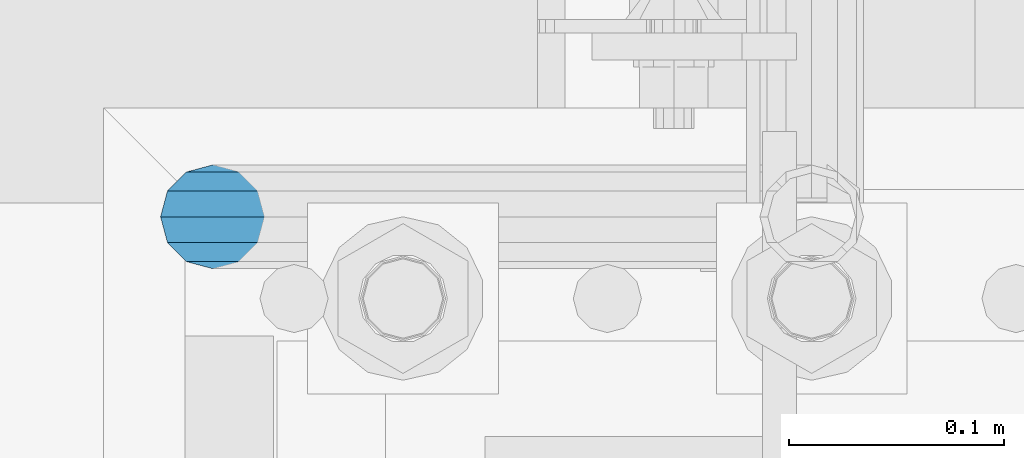
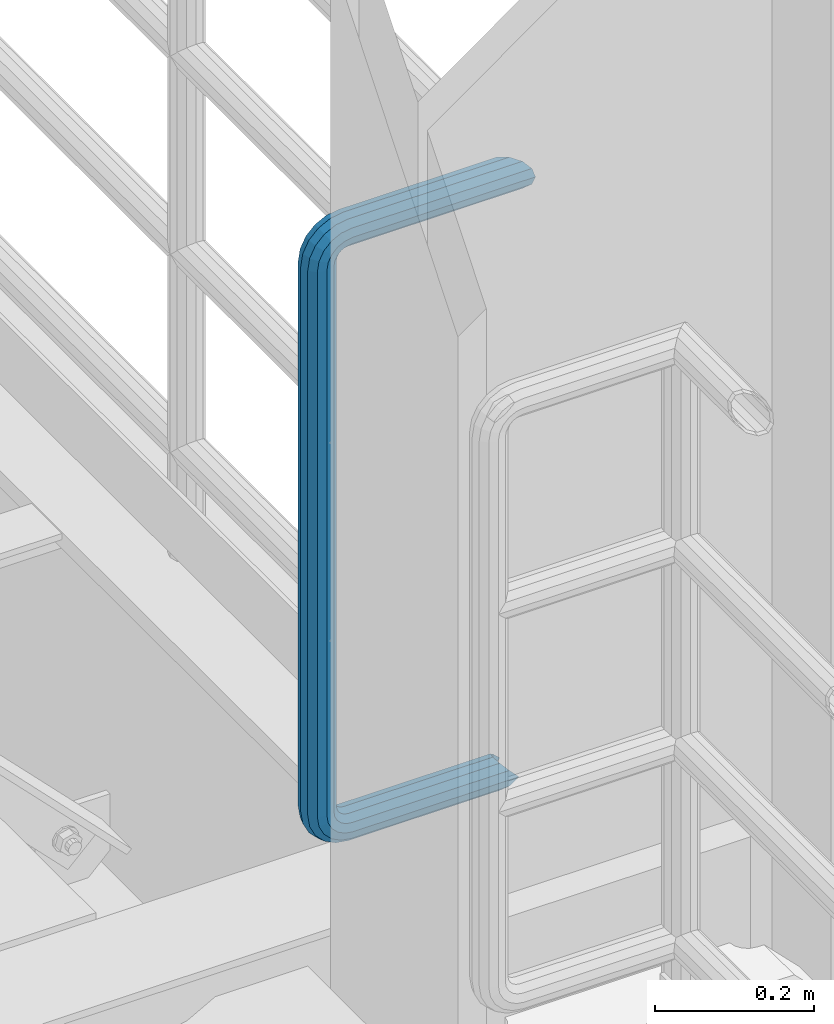
# One storey, part 991 of 1876: 1 beam, 1 element without a shape of its own.
"""IFC2X3 building model written with IfcOpenShell, lengths in millimetres."""

from ifc_helpers import new_model, si_unit, frame, origin_with_axes, place, context, subcontext, project, spatial, faceted_brep, material, type_object, element, aggregate, save


model = new_model("IFC2X3")

# Units and contexts
model_context = context("Model", 3, precision=1e-05, world=origin_with_axes())
body_context = subcontext(model_context, "Body", "Model", "MODEL_VIEW")
ifc_project = project(units=[si_unit("LENGTHUNIT", "METRE", prefix="MILLI"), si_unit("AREAUNIT", "SQUARE_METRE"), si_unit("VOLUMEUNIT", "CUBIC_METRE"), si_unit("MASSUNIT", "GRAM", prefix="KILO"), si_unit("TIMEUNIT", "SECOND"), si_unit("PLANEANGLEUNIT", "RADIAN"), si_unit("SOLIDANGLEUNIT", "STERADIAN"), si_unit("THERMODYNAMICTEMPERATUREUNIT", "DEGREE_CELSIUS"), si_unit("LUMINOUSINTENSITYUNIT", "LUMEN")], contexts=[model_context])

# Site, building, storey
site_placement = place(None, origin_with_axes())
site = spatial("IfcSite", under=ifc_project, at=site_placement, CompositionType="ELEMENT")
building_placement = place(site_placement, origin_with_axes())
building = spatial("IfcBuilding", under=site, at=building_placement, Name="Undefined", CompositionType="ELEMENT")
storey_placement = place(building_placement, origin_with_axes())
storey = spatial("IfcBuildingStorey", under=building, at=storey_placement, Name="Undefined", CompositionType="ELEMENT", Elevation=0.0)

# Assembly, beam
assembly_placement = place(storey_placement, origin_with_axes())
assembly = element("IfcElementAssembly", 1, at=assembly_placement, inside=storey, Name="RAIL", AssemblyPlace="NOTDEFINED", PredefinedType="RIGID_FRAME")
ifc_material = material()
beam_type = type_object("IfcBeamType", Name="PIPE1-1/2SCH40", PredefinedType="NOTDEFINED")
beam_placement = place(assembly_placement, frame((7620.00000000001, -4356.1, 6207.125), z_axis=(0.0, 0.0, 1.0), x_axis=(-1.0, 0.0, 0.0)))
beam = element("IfcBeam", 2, at=beam_placement, type_object=beam_type, material=ifc_material, Name="RAIL", ObjectType="PIPE1-1/2SCH40", context=body_context, shape_type="Brep", body=[
    faceted_brep([(1.20714750983051e-12, 24.1299999999974, -914.399963378906), (12.0650000000014, 20.8971929933159, -926.464963378905), (12.0650000000014, 20.8971929933177, -902.334963378908), (12.0650000000014, -20.8971929933195, -902.334963378908), (12.0650000000014, -20.8971929933195, -926.464963378905), (1.52133659548828e-12, -24.130000000001, -914.399963378906), (20.8971929933199, -12.0650000000023, -893.502770385589), (20.8971929933199, -12.0650000000005, -898.533841947723), (15.2545715621378, -17.7076214311819, -904.176463378906), (12.5151929933181, -20.4470000000019, -914.399963378906), (15.2545715621376, -17.7076214311819, -924.623463378906), (20.8971929933199, -12.0650000000005, -930.26608481009), (20.8971929933199, -12.0650000000023, -935.297156372224), (24.1300000000014, -1.81898940354586e-12, -934.846963378906), (24.1300000000014, -1.81898940354586e-12, -938.529963378907), (21.3906214311813, -10.2235000000019, -932.107584810088), (21.3906214311823, 10.2234999999982, -932.107584810088), (20.8971929933199, 12.0650000000005, -930.266084810086), (20.8971929933199, 12.0649999999987, -935.297156372224), (15.2545715621413, 17.7076214311783, -924.623463378906), (12.5151929933216, 20.4469999999983, -914.399963378906), (15.2545715621411, 17.7076214311783, -904.176463378906), (20.8971929933199, 12.0650000000005, -898.533841947727), (20.8971929933199, 12.0649999999987, -893.502770385589), (21.3906214311822, 10.2234999999982, -896.692341947724), (24.1300000000014, 0.0, -893.952963378906), (24.1300000000014, 0.0, -890.269963378905), (21.3906214311814, -10.2235000000019, -896.692341947724), (241.299995422363, -20.8971929933177, 12.0649999999987), (241.299995422363, -24.1299999999992, 0.0), (253.073542436527, -24.1299999999992, -1.86474665447167), (256.801832473661, -20.8971929933177, 9.60975021462946), (241.299995422363, -12.0650000000005, 20.8971929933177), (259.531130206197, -12.0650000000005, 18.0096649141014), (241.299995422363, 0.0, 24.130000000001), (260.530122510796, 0.0, 21.084247083727), (241.299995422363, 12.0650000000005, 20.8971929933177), (259.531130206197, 12.0650000000005, 18.0096649141014), (241.299995422363, 20.8971929933177, 12.0649999999987), (256.801832473661, 20.8971929933177, 9.60975021462946), (241.299995422363, 24.1299999999992, 0.0), (253.073542436527, 24.1299999999992, -1.86474665447167), (241.299995422363, 20.8971929933177, -12.0649999999987), (249.345252399393, 20.8971929933177, -13.3392435235728), (241.299995422363, 12.0650000000005, -20.8971929933177), (246.615954666858, 12.0650000000005, -21.7391582230448), (241.299995422363, 0.0, -24.130000000001), (245.616962362259, 0.0, -24.8137403926739), (241.299995422363, -12.0650000000005, -20.8971929933177), (246.615954666858, -12.0650000000005, -21.7391582230448), (241.299995422363, -20.8971929933177, -12.0649999999987), (249.345252399393, -20.8971929933177, -13.3392435235728), (267.334993896485, 20.8971929933177, -38.0999984741211), (279.399993896485, 24.1299999999992, -38.0999984741211), (279.399993896484, 24.1299999999992, -876.299964904785), (267.334993896484, 20.8971929933177, -876.299964904785), (291.464993896486, 20.8971929933177, -38.0999984741211), (291.464993896484, 20.8971929933177, -876.299964904785), (300.297186889804, 12.0650000000005, -38.0999984741211), (300.297186889803, 12.0650000000005, -876.299964904785), (303.529993896486, 0.0, -38.0999984741211), (303.529993896484, 0.0, -876.299964904785), (300.297186889804, -12.0650000000005, -38.0999984741211), (300.297186889803, -12.0650000000005, -876.299964904785), (291.464993896486, -20.8971929933177, -38.0999984741211), (291.464993896484, -20.8971929933177, -876.299964904785), (279.399993896484, -24.1299999999992, -38.0999984741211), (279.399993896484, -24.1299999999992, -876.299964904785), (267.334993896485, -20.8971929933177, -38.0999984741211), (267.334993896484, -20.8971929933177, -876.299964904785), (258.502800903167, -12.0650000000005, -38.0999984741211), (258.502800903166, -12.0650000000005, -876.299964904785), (255.269993896485, 0.0, -38.0999984741211), (255.269993896484, 0.0, -876.299964904785), (258.502800903167, 12.0650000000005, -38.0999984741211), (258.502800903166, 12.0650000000005, -876.299964904785), (257.660835673438, 12.0650000000005, -881.615924149282), (254.586253503809, 0.0, -880.616931844681), (257.660835673438, -12.0650000000005, -881.615924149282), (266.06075037291, -20.8971929933177, -884.345221881817), (277.535247242011, -24.130000000001, -888.073511918952), (289.009744111112, -20.8971929933195, -891.801801956084), (297.409658810584, -12.0650000000005, -894.531099688622), (300.484240980214, 0.0, -895.53009199322), (297.409658810584, 12.0650000000005, -894.531099688622), (289.009744111112, 20.8971929933177, -891.801801956084), (277.535247242011, 24.1299999999992, -888.073511918952), (266.06075037291, 20.8971929933177, -884.345221881817), (241.299995422364, -1.81898940354586e-12, -938.529963378911), (241.299995422364, -12.0650000000005, -935.297156372228), (241.299995422364, -20.8971929933195, -926.464963378909), (241.299995422363, -24.130000000001, -914.399963378906), (241.299995422363, -20.8971929933195, -902.334963378908), (241.299995422363, -12.0650000000005, -893.502770385589), (241.299995422363, 0.0, -890.269963378909), (241.299995422364, 20.8971929933177, -926.464963378909), (241.299995422364, 12.0649999999987, -935.297156372228), (241.299995422364, 24.1299999999992, -914.39996337891), (241.299995422363, 20.8971929933177, -902.334963378908), (241.299995422363, 12.0649999999987, -893.502770385589), (260.530122510801, 0.0, -935.484210462637), (259.531130206202, 12.0649999999987, -932.409628293008), (259.531130206201, -12.0650000000005, -932.409628293008), (256.801832473666, -20.8971929933195, -924.009713593536), (253.07354243653, -24.130000000001, -912.535216724435), (249.345252399395, -20.8971929933195, -901.060719855333), (246.615954666859, -12.0650000000005, -892.660805155861), (245.61696236226, 0.0, -889.586222986232), (246.615954666859, 12.0649999999987, -892.660805155861), (249.345252399395, 20.8971929933177, -901.060719855333), (253.07354243653, 24.1299999999992, -912.535216724435), (256.801832473666, 20.8971929933177, -924.009713593536), (275.977674493594, 12.0649999999987, -924.029695422345), (270.786241706733, 20.8971929933177, -916.884301193139), (277.877870775644, 0.0, -926.645091230272), (275.977674493608, -12.0650000000005, -924.029695422334), (270.786241706733, -20.8971929933195, -916.884301193139), (263.694612637823, -24.130000000001, -907.123511156005), (256.602983568912, -20.8971929933195, -897.362721118872), (251.411550782037, -12.0650000000005, -890.21732688968), (249.511354500001, 0.0, -887.601931081743), (251.411550782037, 12.0650000000005, -890.21732688968), (256.602983568912, 20.8971929933177, -897.362721118872), (263.694612637823, 24.1299999999992, -907.123511156005), (281.884331710718, 20.8971929933177, -905.786211189152), (272.123541673585, 24.1299999999992, -898.694582120243), (289.029725939912, 12.0650000000005, -910.977643976028), (291.645121747852, 0.0, -912.877840258065), (289.029725939912, -12.0650000000005, -910.977643976028), (281.884331710718, -20.8971929933195, -905.786211189152), (272.123541673585, -24.130000000001, -898.694582120243), (262.362751636451, -20.8971929933195, -891.602953051333), (255.217357407258, -12.0650000000005, -886.411520264461), (252.601961599318, 0.0, -884.511323982424), (255.217357407258, 12.0650000000005, -886.411520264461), (262.362751636451, 20.8971929933177, -891.602953051333), (266.060750372911, 20.8971929933177, -30.0547414970897), (257.660835673439, 12.0650000000005, -32.7840392296275), (277.535247242011, 24.1299999999992, -26.3264514599541), (289.009744111112, 20.8971929933177, -22.5981614228222), (297.409658810584, 12.0650000000005, -19.8688636902843), (300.484240980213, 0.0, -18.8698713856866), (297.409658810584, -12.0650000000005, -19.8688636902843), (289.009744111112, -20.8971929933177, -22.5981614228222), (277.535247242011, -24.1299999999992, -26.3264514599541), (266.060750372911, -20.8971929933177, -30.0547414970897), (257.660835673439, -12.0650000000005, -32.7840392296275), (254.58625350381, 0.0, -33.7830315342253), (255.217357407257, 12.0650000000005, -27.9884431144455), (252.601961599318, 0.0, -29.8886393964822), (262.362751636451, 20.8971929933177, -22.7970103275729), (272.123541673583, 24.1299999999992, -15.7053812586601), (281.884331710716, 20.8971929933177, -8.61375218975081), (289.029725939909, 12.0650000000005, -3.42231940287456), (291.645121747848, 0.0, -1.52212312084157), (289.029725939909, -12.0650000000005, -3.42231940287456), (281.884331710716, -20.8971929933177, -8.61375218975081), (272.123541673583, -24.1299999999992, -15.7053812586601), (262.362751636451, -20.8971929933177, -22.7970103275729), (255.217357407257, -12.0650000000005, -27.9884431144455), (249.511354500002, 0.0, -26.7980322971671), (251.411550782037, -12.0650000000005, -24.1826364892258), (251.411550782037, 12.0650000000005, -24.1826364892258), (256.602983568912, 20.8971929933177, -17.037242260034), (263.694612637822, 24.1299999999992, -7.27645222290084), (270.786241706732, 20.8971929933177, 2.48433781423228), (275.977674493607, 12.0650000000005, 9.62973204342416), (277.877870775642, 0.0, 12.2451278513654), (275.977674493607, -12.0650000000005, 9.62973204342416), (270.786241706732, -20.8971929933177, 2.48433781423228), (263.694612637822, -24.1299999999992, -7.27645222290084), (256.602983568912, -20.8971929933177, -17.037242260034), (24.1299999999854, -24.1299999999992, 0.0), (20.8971929933039, -20.8971929933177, -12.0649999999987), (12.0649999999854, -12.0650000000005, -20.8971929933177), (20.8971929933249, -12.0650000000005, -20.8971929933177), (16.4810997545745, -16.4810997545883, -16.48109323873), (24.1300000000063, 0.0, -24.130000000001), (-1.45519152283669e-11, 0.0, -24.130000000001), (20.8971929933249, 12.0650000000005, -20.8971929933177), (-12.0650000000145, 12.0650000000005, -20.8971929933177), (-20.897192993333, 20.8971929933177, -12.0649999999987), (-12.0649999999986, 20.8971929933177, -12.0649999999987), (12.0650000000064, 20.8971929933177, -12.0649999999987), (-16.481093238746, 16.4810932387318, -16.4810997545865), (0.0, 24.1299999999992, 0.0), (-24.1300000000145, 24.1299999999992, 0.0), (-20.897192993333, 20.8971929933177, 12.0649999999987), (-12.0650000000145, 12.0650000000005, 20.8971929933177), (-1.45519152283669e-11, 0.0, 24.130000000001), (12.0649999999854, -12.0650000000005, 20.8971929933177), (20.8971929933039, -20.8971929933177, 12.0649999999987), (241.299995422363, -17.7076214311801, 10.2235000000001), (241.299995422363, -20.4470000000001, 0.0), (20.4469999999854, -20.4470000000001, 0.0), (17.7076214311658, -17.7076214311801, 10.2235000000001), (241.299995422363, 0.0, 20.4470000000001), (241.299995422363, -10.2235000000001, 17.7076214311819), (10.2234999999854, -10.2235000000001, 17.7076214311819), (-1.45519152283669e-11, 0.0, 20.4470000000001), (241.299995422363, 10.2235000000001, 17.7076214311819), (-10.2235000000145, 10.2235000000001, 17.7076214311819), (241.299995422363, 17.7076214311801, 10.2235000000001), (-17.7076214311949, 17.7076214311801, 10.2235000000001), (241.299995422363, 20.4470000000001, 0.0), (-20.4470000000145, 20.4470000000001, 0.0), (241.299995422363, 17.7076214311801, -10.2235000000001), (-17.7076214311949, 17.7076214311801, -10.2235000000001), (241.299995422363, 10.2235000000001, -17.7076214311819), (-10.2235000000145, 10.2235000000001, -17.7076214311819), (241.299995422363, 0.0, -20.4470000000001), (-1.45519152283669e-11, 0.0, -20.4470000000001), (241.299995422363, -10.2235000000001, -17.7076214311819), (10.2234999999854, -10.2235000000001, -17.7076214311819), (241.299995422363, -17.7076214311801, -10.2235000000001), (17.7076214311658, -17.7076214311801, -10.2235000000001), (258.545498388721, -10.2235000000001, 14.9762020957387), (256.23277767852, -17.7076214311801, 7.85837963987069), (253.073542436527, -20.4470000000001, -1.86474665447167), (249.914307194535, -17.7076214311801, -11.5878729488177), (247.601586484334, -10.2235000000001, -18.7056954046857), (246.755071952542, 0.0, -21.31099924316), (247.601586484334, 10.2235000000001, -18.7056954046857), (249.914307194535, 17.7076214311801, -11.5878729488177), (253.073542436527, 20.4470000000001, -1.86474665447167), (256.23277767852, 17.7076214311801, 7.85837963987069), (258.545498388721, 10.2235000000001, 14.9762020957387), (259.392012920513, 0.0, 17.5815059342131), (275.713057691449, 0.0, 9.26551826108334), (274.10289136825, -10.2235000000001, 7.04931444488102), (274.10289136825, 10.2235000000001, 7.04931444488102), (269.703835164635, 17.7076214311801, 0.994533019089431), (263.694612637822, 20.4470000000001, -7.27645222290084), (257.685390111009, 17.7076214311801, -15.5474374648911), (253.286333907394, 10.2235000000001, -21.6022188906827), (251.676167584195, 0.0, -23.818422706885), (253.286333907394, -10.2235000000001, -21.6022188906827), (257.685390111009, -17.7076214311801, -15.5474374648911), (263.694612637822, -20.4470000000001, -7.27645222290084), (269.703835164635, -17.7076214311801, 0.994533019089431), (286.449308341364, -10.2235000000001, -5.29710252823133), (280.394526915574, -17.7076214311801, -9.69615873184739), (288.665512157566, 0.0, -3.68693620503473), (286.449308341364, 10.2235000000001, -5.29710252823133), (280.394526915574, 17.7076214311801, -9.69615873184739), (272.123541673583, 20.4470000000001, -15.7053812586601), (263.852556431592, 17.7076214311801, -21.7146037854764), (257.797775005802, 10.2235000000001, -26.1136599890888), (255.581571189601, 0.0, -27.723826312289), (257.797775005802, -10.2235000000001, -26.1136599890888), (263.852556431592, -17.7076214311801, -21.7146037854764), (272.123541673583, -20.4470000000001, -15.7053812586601), (287.258373536355, -17.7076214311801, -23.1672162179639), (277.535247242011, -20.4470000000001, -26.3264514599541), (294.376195992223, -10.2235000000001, -20.8544955077632), (296.981499830698, 0.0, -20.00798097597), (294.376195992223, 10.2235000000001, -20.8544955077632), (287.258373536355, 17.7076214311801, -23.1672162179639), (277.535247242011, 20.4470000000001, -26.3264514599541), (267.812120947668, 17.7076214311801, -29.485686701948), (260.6942984918, 10.2235000000001, -31.7984074121487), (258.088994653325, 0.0, -32.6449219439419), (260.6942984918, -10.2235000000001, -31.7984074121487), (267.812120947668, -17.7076214311801, -29.485686701948), (279.399993896484, -20.4470000000001, -38.0999984741211), (269.176493896485, -17.7076214311801, -38.0999984741211), (289.623493896486, -17.7076214311801, -38.0999984741211), (297.107615327666, -10.2235000000001, -38.0999984741211), (299.846993896486, 0.0, -38.0999984741211), (297.107615327666, 10.2235000000001, -38.0999984741211), (289.623493896486, 17.7076214311801, -38.0999984741211), (279.399993896485, 20.4470000000001, -38.0999984741211), (269.176493896485, 17.7076214311801, -38.0999984741211), (261.692372465305, 10.2235000000001, -38.0999984741211), (258.952993896485, 0.0, -38.0999984741211), (261.692372465305, -10.2235000000001, -38.0999984741211), (269.176493896484, -17.7076214311801, -876.299964904785), (261.692372465304, -10.2235000000001, -876.299964904785), (258.952993896484, 0.0, -876.299964904785), (261.692372465304, 10.2235000000001, -876.299964904785), (269.176493896484, 17.7076214311801, -876.299964904785), (279.399993896484, 20.4470000000001, -876.299964904785), (289.623493896484, 17.7076214311801, -876.299964904785), (297.107615327665, 10.2235000000001, -876.299964904785), (299.846993896484, 0.0, -876.299964904785), (297.107615327665, -10.2235000000001, -876.299964904785), (289.623493896484, -17.7076214311801, -876.299964904785), (279.399993896484, -20.4470000000001, -876.299964904785), (277.535247242011, -20.4470000000001, -888.073511918952), (267.812120947667, -17.7076214311801, -884.914276676958), (260.694298491799, -10.2235000000001, -882.601555966758), (258.088994653324, 0.0, -881.755041434964), (260.694298491799, 10.2235000000001, -882.601555966758), (267.812120947668, 17.7076214311801, -884.914276676958), (277.535247242011, 20.4470000000001, -888.073511918952), (287.258373536355, 17.7076214311801, -891.232747160942), (294.376195992223, 10.2235000000001, -893.545467871143), (296.981499830699, 0.0, -894.391982402936), (294.376195992223, -10.2235000000001, -893.545467871143), (287.258373536355, -17.7076214311801, -891.232747160942), (280.394526915577, -17.7076214311801, -904.703804647055), (272.123541673585, -20.4470000000001, -898.694582120243), (286.449308341367, -10.2235000000001, -909.102860850671), (288.665512157569, 0.0, -910.713027173868), (286.449308341367, 10.2235000000001, -909.102860850671), (280.394526915577, 17.7076214311801, -904.703804647055), (272.123541673585, 20.4470000000001, -898.694582120243), (263.852556431593, 17.7076214311801, -892.68535959343), (257.797775005802, 10.2235000000001, -888.286303389817), (255.581571189601, 0.0, -886.676137066617), (257.797775005802, -10.2235000000001, -888.286303389817), (263.852556431593, -17.7076214311801, -892.68535959343), (263.694612637823, -20.4470000000001, -907.123511156005), (257.685390111009, -17.7076214311801, -898.852525914015), (269.703835164636, -17.7076214311801, -915.394496397999), (274.102891368238, -10.2235000000001, -921.449277823798), (275.71305769145, 0.0, -923.66548163999), (274.102891368251, 10.2235000000001, -921.449277823787), (269.703835164636, 17.7076214311801, -915.394496397999), (263.694612637823, 20.4470000000001, -907.123511156005), (257.685390111009, 17.7076214311801, -898.852525914015), (253.286333907394, 10.2235000000001, -892.797744488227), (251.676167584195, 0.0, -890.581540672025), (253.286333907394, -10.2235000000001, -892.797744488227), (249.914307194537, -17.7076214311801, -902.812090430092), (247.601586484335, -10.2235000000001, -895.694267974224), (253.07354243653, -20.4470000000001, -912.535216724435), (256.232777678524, -17.7076214311819, -922.258343018777), (258.545498388725, -10.2235000000001, -929.376165474645), (259.392012920517, 0.0, -931.981469313119), (258.545498388725, 10.2235000000001, -929.376165474645), (256.232777678524, 17.7076214311801, -922.258343018777), (253.07354243653, 20.4470000000001, -912.535216724435), (249.914307194537, 17.7076214311801, -902.812090430092), (247.601586484335, 10.2235000000001, -895.694267974224), (246.755071952543, 0.0, -893.088964135746), (241.299995422363, -10.2235000000001, -896.692341947728), (241.299995422363, 0.0, -893.95296337891), (241.299995422363, -17.7076214311819, -904.17646337891), (241.299995422363, -20.4470000000001, -914.399963378906), (241.299995422364, -17.7076214311819, -924.62346337891), (241.299995422364, -10.2235000000001, -932.107584810088), (241.299995422364, -1.81898940354586e-12, -934.84696337891), (241.299995422364, 10.2234999999982, -932.107584810088), (241.299995422364, 17.7076214311801, -924.62346337891), (241.299995422364, 20.4470000000001, -914.39996337891), (241.299995422363, 17.7076214311801, -904.17646337891), (241.299995422363, 10.2235000000001, -896.692341947728)], [[[0, 1, 2]], [[3, 4, 5]], [[6, 7, 8, 9, 10, 11, 12, 4, 3]], [[13, 14, 12, 11, 15]], [[16, 17, 18, 14, 13]], [[2, 1, 18, 17, 19, 20, 21, 22, 23]], [[23, 22, 24, 25, 26]], [[26, 25, 27, 7, 6]], [[28, 29, 30, 31]], [[32, 28, 31, 33]], [[34, 32, 33, 35]], [[36, 34, 35, 37]], [[38, 36, 37, 39]], [[40, 38, 39, 41]], [[42, 40, 41, 43]], [[44, 42, 43, 45]], [[46, 44, 45, 47]], [[48, 46, 47, 49]], [[50, 48, 49, 51]], [[52, 53, 54, 55]], [[53, 56, 57, 54]], [[56, 58, 59, 57]], [[58, 60, 61, 59]], [[60, 62, 63, 61]], [[62, 64, 65, 63]], [[64, 66, 67, 65]], [[66, 68, 69, 67]], [[68, 70, 71, 69]], [[70, 72, 73, 71]], [[72, 74, 75, 73]], [[73, 75, 76, 77]], [[71, 73, 77, 78]], [[69, 71, 78, 79]], [[67, 69, 79, 80]], [[65, 67, 80, 81]], [[63, 65, 81, 82]], [[61, 63, 82, 83]], [[59, 61, 83, 84]], [[57, 59, 84, 85]], [[54, 57, 85, 86]], [[55, 54, 86, 87]], [[88, 89, 12, 14]], [[89, 90, 4, 12]], [[90, 91, 5, 4]], [[91, 92, 3, 5]], [[92, 93, 6, 3]], [[93, 94, 26, 6]], [[95, 96, 18, 1]], [[97, 95, 1, 0]], [[98, 97, 0, 2]], [[99, 98, 2, 23]], [[94, 99, 23, 26]], [[96, 88, 14, 18]], [[100, 88, 96, 101]], [[102, 89, 88, 100]], [[103, 90, 89, 102]], [[104, 91, 90, 103]], [[105, 92, 91, 104]], [[106, 93, 92, 105]], [[107, 94, 93, 106]], [[108, 99, 94, 107]], [[109, 98, 99, 108]], [[110, 97, 98, 109]], [[111, 95, 97, 110]], [[101, 96, 95, 111]], [[112, 101, 111, 113]], [[114, 100, 101, 112]], [[115, 102, 100, 114]], [[116, 103, 102, 115]], [[117, 104, 103, 116]], [[118, 105, 104, 117]], [[119, 106, 105, 118]], [[120, 107, 106, 119]], [[121, 108, 107, 120]], [[122, 109, 108, 121]], [[123, 110, 109, 122]], [[113, 111, 110, 123]], [[124, 113, 123, 125]], [[126, 112, 113, 124]], [[127, 114, 112, 126]], [[128, 115, 114, 127]], [[129, 116, 115, 128]], [[130, 117, 116, 129]], [[131, 118, 117, 130]], [[132, 119, 118, 131]], [[133, 120, 119, 132]], [[134, 121, 120, 133]], [[135, 122, 121, 134]], [[125, 123, 122, 135]], [[86, 125, 135, 87]], [[85, 124, 125, 86]], [[84, 126, 124, 85]], [[83, 127, 126, 84]], [[82, 128, 127, 83]], [[81, 129, 128, 82]], [[80, 130, 129, 81]], [[79, 131, 130, 80]], [[78, 132, 131, 79]], [[77, 133, 132, 78]], [[76, 134, 133, 77]], [[87, 135, 134, 76]], [[75, 55, 87, 76]], [[74, 52, 55, 75]], [[136, 52, 74, 137]], [[138, 53, 52, 136]], [[139, 56, 53, 138]], [[140, 58, 56, 139]], [[141, 60, 58, 140]], [[142, 62, 60, 141]], [[143, 64, 62, 142]], [[144, 66, 64, 143]], [[145, 68, 66, 144]], [[146, 70, 68, 145]], [[147, 72, 70, 146]], [[137, 74, 72, 147]], [[148, 137, 147, 149]], [[150, 136, 137, 148]], [[151, 138, 136, 150]], [[152, 139, 138, 151]], [[153, 140, 139, 152]], [[154, 141, 140, 153]], [[155, 142, 141, 154]], [[156, 143, 142, 155]], [[157, 144, 143, 156]], [[158, 145, 144, 157]], [[159, 146, 145, 158]], [[149, 147, 146, 159]], [[160, 149, 159, 161]], [[162, 148, 149, 160]], [[163, 150, 148, 162]], [[164, 151, 150, 163]], [[165, 152, 151, 164]], [[166, 153, 152, 165]], [[167, 154, 153, 166]], [[168, 155, 154, 167]], [[169, 156, 155, 168]], [[170, 157, 156, 169]], [[171, 158, 157, 170]], [[161, 159, 158, 171]], [[49, 161, 171, 51]], [[47, 160, 161, 49]], [[45, 162, 160, 47]], [[43, 163, 162, 45]], [[41, 164, 163, 43]], [[39, 165, 164, 41]], [[37, 166, 165, 39]], [[35, 167, 166, 37]], [[33, 168, 167, 35]], [[31, 169, 168, 33]], [[30, 170, 169, 31]], [[51, 171, 170, 30]], [[29, 50, 51, 30]], [[50, 29, 172, 173]], [[174, 175, 48, 50, 173, 176]], [[177, 46, 48, 175, 174, 178]], [[179, 44, 46, 177, 178, 180]], [[181, 182, 183, 42, 44, 179, 180, 184]], [[185, 40, 42, 183, 182, 181, 186]], [[38, 40, 185, 186, 187]], [[36, 38, 187, 188]], [[34, 36, 188, 189]], [[32, 34, 189, 190]], [[28, 32, 190, 191]], [[29, 28, 191, 172]], [[192, 193, 194, 195]], [[196, 197, 198, 199]], [[200, 196, 199, 201]], [[202, 200, 201, 203]], [[204, 202, 203, 205]], [[206, 204, 205, 207]], [[208, 206, 207, 209]], [[210, 208, 209, 211]], [[212, 210, 211, 213]], [[214, 212, 213, 215]], [[193, 214, 215, 194]], [[190, 189, 188, 187, 186, 181, 184, 180, 178, 174, 176, 173, 172, 191], [213, 211, 209, 207, 205, 203, 201, 199, 198, 195, 194, 215]], [[197, 192, 195, 198]], [[192, 197, 216, 217]], [[193, 192, 217, 218]], [[214, 193, 218, 219]], [[212, 214, 219, 220]], [[210, 212, 220, 221]], [[208, 210, 221, 222]], [[206, 208, 222, 223]], [[204, 206, 223, 224]], [[202, 204, 224, 225]], [[200, 202, 225, 226]], [[196, 200, 226, 227]], [[197, 196, 227, 216]], [[227, 228, 229, 216]], [[226, 230, 228, 227]], [[225, 231, 230, 226]], [[224, 232, 231, 225]], [[223, 233, 232, 224]], [[222, 234, 233, 223]], [[221, 235, 234, 222]], [[220, 236, 235, 221]], [[219, 237, 236, 220]], [[218, 238, 237, 219]], [[217, 239, 238, 218]], [[216, 229, 239, 217]], [[229, 240, 241, 239]], [[228, 242, 240, 229]], [[230, 243, 242, 228]], [[231, 244, 243, 230]], [[232, 245, 244, 231]], [[233, 246, 245, 232]], [[234, 247, 246, 233]], [[235, 248, 247, 234]], [[236, 249, 248, 235]], [[237, 250, 249, 236]], [[238, 251, 250, 237]], [[239, 241, 251, 238]], [[241, 252, 253, 251]], [[240, 254, 252, 241]], [[242, 255, 254, 240]], [[243, 256, 255, 242]], [[244, 257, 256, 243]], [[245, 258, 257, 244]], [[246, 259, 258, 245]], [[247, 260, 259, 246]], [[248, 261, 260, 247]], [[249, 262, 261, 248]], [[250, 263, 262, 249]], [[251, 253, 263, 250]], [[253, 264, 265, 263]], [[252, 266, 264, 253]], [[254, 267, 266, 252]], [[255, 268, 267, 254]], [[256, 269, 268, 255]], [[257, 270, 269, 256]], [[258, 271, 270, 257]], [[259, 272, 271, 258]], [[260, 273, 272, 259]], [[261, 274, 273, 260]], [[262, 275, 274, 261]], [[263, 265, 275, 262]], [[275, 265, 276, 277]], [[274, 275, 277, 278]], [[273, 274, 278, 279]], [[272, 273, 279, 280]], [[271, 272, 280, 281]], [[270, 271, 281, 282]], [[269, 270, 282, 283]], [[268, 269, 283, 284]], [[267, 268, 284, 285]], [[266, 267, 285, 286]], [[264, 266, 286, 287]], [[265, 264, 287, 276]], [[276, 287, 288, 289]], [[277, 276, 289, 290]], [[278, 277, 290, 291]], [[279, 278, 291, 292]], [[280, 279, 292, 293]], [[281, 280, 293, 294]], [[282, 281, 294, 295]], [[283, 282, 295, 296]], [[284, 283, 296, 297]], [[285, 284, 297, 298]], [[286, 285, 298, 299]], [[287, 286, 299, 288]], [[299, 300, 301, 288]], [[298, 302, 300, 299]], [[297, 303, 302, 298]], [[296, 304, 303, 297]], [[295, 305, 304, 296]], [[294, 306, 305, 295]], [[293, 307, 306, 294]], [[292, 308, 307, 293]], [[291, 309, 308, 292]], [[290, 310, 309, 291]], [[289, 311, 310, 290]], [[288, 301, 311, 289]], [[301, 312, 313, 311]], [[300, 314, 312, 301]], [[302, 315, 314, 300]], [[303, 316, 315, 302]], [[304, 317, 316, 303]], [[305, 318, 317, 304]], [[306, 319, 318, 305]], [[307, 320, 319, 306]], [[308, 321, 320, 307]], [[309, 322, 321, 308]], [[310, 323, 322, 309]], [[311, 313, 323, 310]], [[313, 324, 325, 323]], [[312, 326, 324, 313]], [[314, 327, 326, 312]], [[315, 328, 327, 314]], [[316, 329, 328, 315]], [[317, 330, 329, 316]], [[318, 331, 330, 317]], [[319, 332, 331, 318]], [[320, 333, 332, 319]], [[321, 334, 333, 320]], [[322, 335, 334, 321]], [[323, 325, 335, 322]], [[325, 336, 337, 335]], [[324, 338, 336, 325]], [[326, 339, 338, 324]], [[327, 340, 339, 326]], [[328, 341, 340, 327]], [[329, 342, 341, 328]], [[330, 343, 342, 329]], [[331, 344, 343, 330]], [[332, 345, 344, 331]], [[333, 346, 345, 332]], [[334, 347, 346, 333]], [[335, 337, 347, 334]], [[347, 337, 25, 24]], [[21, 346, 347, 24, 22]], [[345, 346, 21, 20]], [[344, 345, 20, 19]], [[343, 344, 19, 17, 16]], [[342, 343, 16, 13]], [[341, 342, 13, 15]], [[10, 340, 341, 15, 11]], [[339, 340, 10, 9]], [[338, 339, 9, 8]], [[336, 338, 8, 7, 27]], [[337, 336, 27, 25]]]),
])
aggregate(assembly, [beam])

save(model, "model.ifc")
